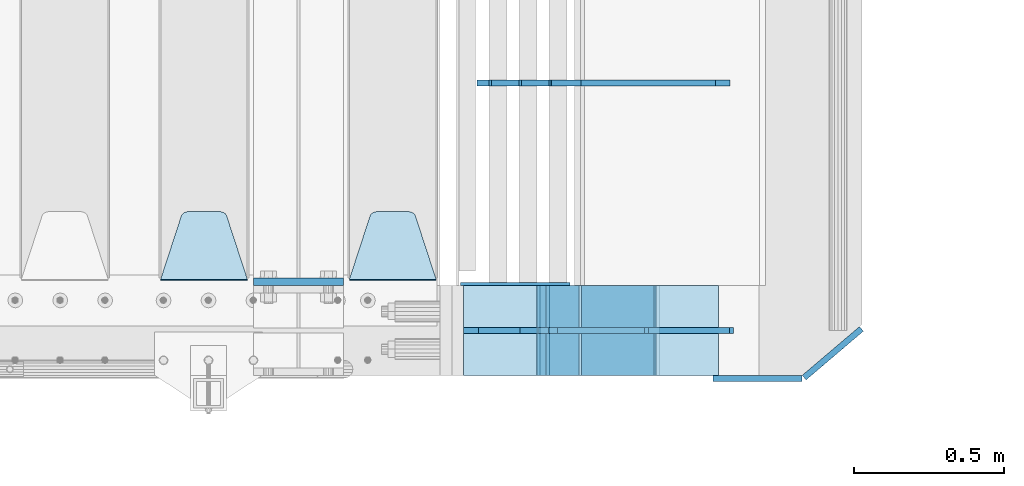
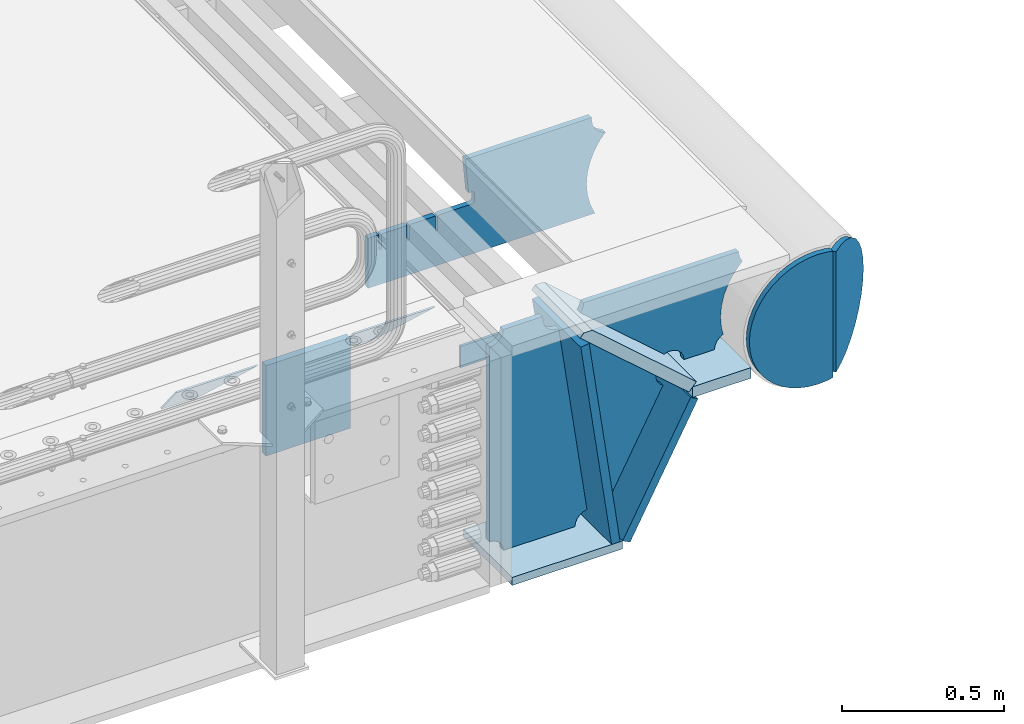
# One storey, part 224 of 247: 15 plates.
"""IFC2X3 building model written with IfcOpenShell, lengths in millimetres."""

from ifc_helpers import new_model, si_unit, frame, origin_with_axes, place, context, subcontext, project, spatial, faceted_brep, material, type_object, element, save


model = new_model("IFC2X3")

# Units and contexts
model_context = context("Model", 3, precision=1e-05, world=origin_with_axes())
body_context = subcontext(model_context, "Body", "Model", "MODEL_VIEW")
ifc_project = project(units=[si_unit("LENGTHUNIT", "METRE", prefix="MILLI"), si_unit("AREAUNIT", "SQUARE_METRE"), si_unit("VOLUMEUNIT", "CUBIC_METRE"), si_unit("MASSUNIT", "GRAM", prefix="KILO"), si_unit("TIMEUNIT", "SECOND"), si_unit("PLANEANGLEUNIT", "RADIAN"), si_unit("SOLIDANGLEUNIT", "STERADIAN"), si_unit("THERMODYNAMICTEMPERATUREUNIT", "DEGREE_CELSIUS"), si_unit("LUMINOUSINTENSITYUNIT", "LUMEN")], contexts=[model_context])

# Site, building, storey
site_placement = place(None, origin_with_axes())
site = spatial("IfcSite", under=ifc_project, at=site_placement, CompositionType="ELEMENT")
building_placement = place(site_placement, origin_with_axes())
building = spatial("IfcBuilding", under=site, at=building_placement, Name="Standard", CompositionType="ELEMENT")
storey_placement = place(building_placement, origin_with_axes())
storey = spatial("IfcBuildingStorey", under=building, at=storey_placement, Name="Undefined", CompositionType="ELEMENT", Elevation=0.0)

# Plates
ifc_material = material(Name="STEEL/S355N")
plate_type_1 = type_object("IfcPlateType", PredefinedType="NOTDEFINED")
plate_1_placement = place(storey_placement, frame((16195.0, 162.5, -340.000000000044), z_axis=(0.0, 0.0, 1.0), x_axis=(1.0, 0.0, 0.0)))
element("IfcPlate", 1, at=plate_1_placement, inside=storey, type_object=plate_type_1, material=ifc_material, context=body_context, shape_type="Brep", body=[
    faceted_brep([(0.0, -12.5, 0.0), (0.0, -12.5, 340.0), (0.0, 12.5, 340.0), (0.0, 12.5, 0.0), (300.0, -12.5, 340.0), (300.0, 12.5, 340.0), (300.0, -12.5, 0.0), (300.0, 12.5, 0.0)], [[[0, 1, 2, 3]], [[1, 4, 5, 2]], [[4, 6, 7, 5]], [[6, 0, 3, 7]], [[5, 7, 3, 2]], [[6, 4, 1, 0]]]),
])
plate_type_2 = type_object("IfcPlateType", PredefinedType="NOTDEFINED")
plate_2_placement = place(storey_placement, frame((16805.0, 168.232233047034, -1.76776695296758), z_axis=(0.0, 0.707106781186548, -0.707106781186547), x_axis=(-1.0, 0.0, 0.0)))
element("IfcPlate", 2, at=plate_2_placement, inside=storey, type_object=plate_type_2, material=ifc_material, context=body_context, shape_type="Brep", body=[
    faceted_brep([(0.0, -2.49999999999909, 0.0), (69.345504679477, -2.5, 300.17173142483), (69.345504679477, 2.50000000000091, 300.171731424831), (0.0, 2.5, -9.09494701772928e-13), (70.9274061199576, -2.5, 304.897442415399), (70.9274061199576, 2.50000000000091, 304.8974424154), (73.3818627772307, -2.49999999999909, 309.234538108527), (73.3818627772307, 2.5, 309.234538108526), (76.6187032999551, -2.5, 313.023683126102), (76.6187032999551, 2.50000000000091, 313.023683126102), (80.5190132704993, -2.49999999999909, 316.125672595371), (80.5190132704993, 2.50000000000091, 316.125672595372), (84.9395038596849, -2.49999999999909, 318.426546230476), (84.9395038596849, 2.5, 318.426546230475), (89.7177759439219, -2.5, 319.841774983274), (89.7177759439219, 2.50000000000091, 319.841774983275), (94.678286292652, -2.5, 320.319366455077), (94.678286292652, 2.50000000000091, 320.319366455077), (195.321713707348, -2.5, 320.319366455077), (195.321713707348, 2.50000000000091, 320.319366455077), (200.282224056078, -2.5, 319.841774983274), (200.282224056078, 2.50000000000091, 319.841774983275), (205.060496140315, -2.5, 318.426546230475), (205.060496140315, 2.5, 318.426546230474), (209.480986729501, -2.49999999999818, 316.12567259537), (209.480986729501, 2.50000000000091, 316.12567259537), (213.381296700045, -2.5, 313.023683126101), (213.381296700045, 2.50000000000091, 313.023683126101), (216.618137222769, -2.5, 309.234538108525), (216.618137222769, 2.5, 309.234538108525), (219.072593880042, -2.49999999999909, 304.897442415398), (219.072593880042, 2.5, 304.897442415398), (220.654495320523, -2.5, 300.17173142483), (220.654495320523, 2.50000000000091, 300.171731424831), (290.0, -2.49999999999909, 0.0), (290.0, 2.5, -9.09494701772928e-13)], [[[0, 1, 2, 3]], [[1, 4, 5, 2]], [[4, 6, 7, 5]], [[6, 8, 9, 7]], [[8, 10, 11, 9]], [[10, 12, 13, 11]], [[12, 14, 15, 13]], [[14, 16, 17, 15]], [[16, 18, 19, 17]], [[18, 20, 21, 19]], [[20, 22, 23, 21]], [[22, 24, 25, 23]], [[24, 26, 27, 25]], [[26, 28, 29, 27]], [[28, 30, 31, 29]], [[30, 32, 33, 31]], [[32, 34, 35, 33]], [[34, 0, 3, 35]], [[5, 7, 9, 11, 13, 15, 17, 19, 21, 23, 25, 27, 29, 31, 33, 35, 3, 2]], [[34, 32, 30, 28, 26, 24, 22, 20, 18, 16, 14, 12, 10, 8, 6, 4, 1, 0]]]),
])
plate_3_placement = place(storey_placement, frame((16175.0, 168.232233047034, -1.76776695296758), z_axis=(0.0, 0.707106781186548, -0.707106781186547), x_axis=(-1.0, 0.0, 0.0)))
element("IfcPlate", 3, at=plate_3_placement, inside=storey, type_object=plate_type_2, material=ifc_material, context=body_context, shape_type="Brep", body=[
    faceted_brep([(0.0, -2.49999999999909, 0.0), (69.345504679477, -2.5, 300.17173142483), (69.345504679477, 2.50000000000091, 300.171731424831), (0.0, 2.5, -9.09494701772928e-13), (70.9274061199576, -2.5, 304.897442415399), (70.9274061199576, 2.50000000000091, 304.8974424154), (73.3818627772307, -2.49999999999909, 309.234538108527), (73.3818627772307, 2.5, 309.234538108526), (76.6187032999551, -2.5, 313.023683126102), (76.6187032999551, 2.50000000000091, 313.023683126102), (80.5190132704993, -2.49999999999909, 316.125672595371), (80.5190132704993, 2.50000000000091, 316.125672595372), (84.9395038596849, -2.49999999999909, 318.426546230476), (84.9395038596849, 2.5, 318.426546230475), (89.7177759439219, -2.5, 319.841774983274), (89.7177759439219, 2.50000000000091, 319.841774983275), (94.678286292652, -2.5, 320.319366455077), (94.678286292652, 2.50000000000091, 320.319366455077), (195.321713707348, -2.5, 320.319366455077), (195.321713707348, 2.50000000000091, 320.319366455077), (200.282224056078, -2.5, 319.841774983274), (200.282224056078, 2.50000000000091, 319.841774983275), (205.060496140315, -2.5, 318.426546230475), (205.060496140315, 2.5, 318.426546230474), (209.480986729501, -2.49999999999818, 316.12567259537), (209.480986729501, 2.50000000000091, 316.12567259537), (213.381296700045, -2.5, 313.023683126101), (213.381296700045, 2.50000000000091, 313.023683126101), (216.618137222769, -2.5, 309.234538108525), (216.618137222769, 2.5, 309.234538108525), (219.072593880042, -2.49999999999909, 304.897442415398), (219.072593880042, 2.5, 304.897442415398), (220.654495320523, -2.5, 300.17173142483), (220.654495320523, 2.50000000000091, 300.171731424831), (290.0, -2.49999999999909, 0.0), (290.0, 2.5, -9.09494701772928e-13)], [[[0, 1, 2, 3]], [[1, 4, 5, 2]], [[4, 6, 7, 5]], [[6, 8, 9, 7]], [[8, 10, 11, 9]], [[10, 12, 13, 11]], [[12, 14, 15, 13]], [[14, 16, 17, 15]], [[16, 18, 19, 17]], [[18, 20, 21, 19]], [[20, 22, 23, 21]], [[22, 24, 25, 23]], [[24, 26, 27, 25]], [[26, 28, 29, 27]], [[28, 30, 31, 29]], [[30, 32, 33, 31]], [[32, 34, 35, 33]], [[34, 0, 3, 35]], [[5, 7, 9, 11, 13, 15, 17, 19, 21, 23, 25, 27, 29, 31, 33, 35, 3, 2]], [[34, 32, 30, 28, 26, 24, 22, 20, 18, 16, 14, 12, 10, 8, 6, 4, 1, 0]]]),
])
plate_type_3 = type_object("IfcPlateType", PredefinedType="NOTDEFINED")
plate_4_placement = place(storey_placement, frame((17538.9988298898, 149.9999999992, -367.999999998825), z_axis=(-0.752989422949573, 0.0, 0.658032619955933), x_axis=(0.0, -0.999999999999548, -9.5100000000016e-07)))
element("IfcPlate", 4, at=plate_4_placement, inside=storey, type_object=plate_type_3, material=ifc_material, context=body_context, shape_type="Brep", body=[
    faceted_brep([(-8.10757683211705e-10, 19.9999999999982, 490.766265601622), (4.54747350886464e-13, -0.303811250943909, 513.999999999998), (300.0, -0.303811250943909, 513.999999999998), (300.0, 19.9999999999982, 490.766265601622), (300.0, -20.0, -1.81898940354586e-12), (300.0, -20.0000000000018, 514.0), (4.54747350886464e-13, -20.0000000000018, 514.0), (0.0, -20.0, 0.0), (0.0, 20.0, 0.0), (300.0, 20.0, -1.81898940354586e-12)], [[[0, 1, 2, 3]], [[4, 5, 6, 7]], [[4, 7, 8, 9]], [[9, 8, 0, 3]], [[5, 4, 9, 3, 2]], [[6, 5, 2, 1]], [[8, 7, 6, 1, 0]]]),
])
plate_type_4 = type_object("IfcPlateType", PredefinedType="NOTDEFINED")
plate_5_placement = place(storey_placement, frame((17782.9182339676, 824.999282836914, -374.002067436517), z_axis=(0.0, 0.0, 1.0), x_axis=(-1.0, 0.0, 0.0)))
element("IfcPlate", 5, at=plate_5_placement, inside=storey, type_object=plate_type_4, material=ifc_material, context=body_context, shape_type="Brep", body=[
    faceted_brep([(801.919404066546, -10.0, 188.0), (801.919404066546, 10.0, 188.0), (801.919404066546, 10.0, 132.002067436952), (801.919404066546, -10.0, 132.002067436952), (793.919404066546, 10.0, 132.002067436952), (793.919404066546, -10.0, 132.002067436952), (793.919404066546, 10.0, 180.002067436952), (793.919404066546, -10.0, 180.002067436952), (793.527856196906, 10.0, 182.474203391951), (793.527856196906, -10.0, 182.474203391951), (792.391540021545, 10.0, 184.704349455291), (792.391540021545, -10.0, 184.704349455291), (790.621686084887, 10.0, 186.474203391951), (790.621686084887, -10.0, 186.474203391951), (788.391540021545, 10.0, 187.610519567313), (788.391540021545, -10.0, 187.610519567313), (785.919404066546, -10.0, 188.002067436952), (785.919404066546, 10.0, 188.0), (841.0, -10.0, 188.0), (841.0, -10.0, 0.0), (841.0, 10.0, 0.0), (841.0, 10.0, 188.0), (33.3619566736015, -10.0, 0.0), (33.3619566736015, 10.0, 0.0), (36.2350612208174, -10.0, 4.68848050267013), (36.2350612208174, 10.0, 4.68848050267013), (51.4877592159428, -10.0, 41.5117508652784), (51.4877592159428, 10.0, 41.5117508652784), (60.792242588137, -10.0, 80.2677133162964), (60.792242588137, 10.0, 80.2677133162964), (63.9194040769726, -10.0, 120.002067436515), (63.9194040769726, 10.0, 120.002067436515), (60.792242588137, -10.0, 159.736421556734), (60.792242588137, 10.0, 159.736421556734), (51.4877592159428, -10.0, 198.492384007752), (51.4877592159428, 10.0, 198.492384007752), (36.2350612208174, -10.0, 235.31565437036), (36.2350612208174, 10.0, 235.31565437036), (15.4097206482074, -10.0, 269.299521518803), (15.4097206482074, 10.0, 269.299521518803), (-3.35474438098754, -10.0, 291.269887256574), (-3.35474438098754, 10.0, 291.269887256574), (-2.36881039375294, -10.0, 291.426043859339), (-2.36881039375294, 10.0, 291.426043859339), (17.1449676604716, -10.0, 301.368810393754), (17.1449676604716, 10.0, 301.368810393754), (32.6311896062471, -10.0, 316.855032339527), (32.6311896062471, 10.0, 316.855032339527), (42.573956140659, -10.0, 336.368810393754), (42.573956140659, 10.0, 336.368810393754), (46.0, -10.0, 358.0), (46.0, 10.0, 358.0), (45.0495205499137, -10.0, 364.001091067617), (45.0495205499137, 10.0, 364.001091067617), (495.040008544922, -10.0, 364.010009765625), (495.040008544922, 10.0, 364.010009765625), (483.600036621094, -10.0, 233.759994506836), (483.600036621094, 10.0, 233.759994506836), (472.0, -10.0, 233.759994506836), (472.0, 10.0, 233.759994506836), (468.909830056251, -10.0, 233.270559669787), (468.909830056251, 10.0, 233.270559669787), (466.122147477075, -10.0, 231.850164450585), (466.122147477075, 10.0, 231.850164450585), (463.909830056251, -10.0, 229.637847029761), (463.909830056251, 10.0, 229.637847029761), (462.489434837047, -10.0, 226.850164450585), (462.489434837047, 10.0, 226.850164450585), (462.0, -10.0, 223.759994506836), (462.0, 10.0, 223.759994506836), (462.0, -10.0, 198.0), (462.0, 10.0, 198.0), (462.489434837047, -10.0, 194.909830056251), (462.489434837047, 10.0, 194.909830056251), (463.909830056251, -10.0, 192.122147477075), (463.909830056251, 10.0, 192.122147477075), (466.122147477075, -10.0, 189.909830056251), (466.122147477075, 10.0, 189.909830056251), (468.909830056251, -10.0, 188.489434837048), (468.909830056251, 10.0, 188.489434837048), (472.0, -10.0, 188.0), (472.0, 10.0, 188.0), (585.919404066546, -10.0, 188.002067436952), (585.919404066546, 10.0, 188.0), (588.391540021545, -10.0, 187.610519567313), (588.391540021545, 10.0, 187.610519567313), (590.621686084887, -10.0, 186.474203391951), (590.621686084887, 10.0, 186.474203391951), (592.391540021545, -10.0, 184.704349455291), (592.391540021545, 10.0, 184.704349455291), (593.527856196906, -10.0, 182.474203391951), (593.527856196906, 10.0, 182.474203391951), (593.919404066546, -10.0, 180.002067436952), (593.919404066546, 10.0, 180.002067436952), (593.919404066546, -10.0, 132.002067436952), (593.919404066546, 10.0, 132.002067436952), (601.919404066546, -10.0, 132.002067436952), (601.919404066546, 10.0, 132.002067436952), (601.919404066546, -10.0, 188.0), (601.919404066546, 10.0, 188.0), (685.919404066546, -10.0, 188.002067436952), (685.919404066546, 10.0, 188.0), (688.391540021545, -10.0, 187.610519567313), (688.391540021545, 10.0, 187.610519567313), (690.621686084887, -10.0, 186.474203391951), (690.621686084887, 10.0, 186.474203391951), (692.391540021545, -10.0, 184.704349455291), (692.391540021545, 10.0, 184.704349455291), (693.527856196906, -10.0, 182.474203391951), (693.527856196906, 10.0, 182.474203391951), (693.919404066546, -10.0, 180.002067436952), (693.919404066546, 10.0, 180.002067436952), (693.919404066546, -10.0, 132.002067436952), (693.919404066546, 10.0, 132.002067436952), (701.919404066546, -10.0, 132.002067436952), (701.919404066546, 10.0, 132.002067436952), (701.919404066546, -10.0, 188.0), (701.919404066546, 10.0, 188.0)], [[[0, 1, 2, 3]], [[3, 2, 4, 5]], [[5, 4, 6, 7]], [[7, 6, 8, 9]], [[9, 8, 10, 11]], [[11, 10, 12, 13]], [[13, 12, 14, 15]], [[16, 15, 14, 17]], [[18, 19, 20, 21]], [[20, 19, 22, 23]], [[22, 24, 25, 23]], [[26, 27, 25, 24]], [[28, 29, 27, 26]], [[30, 31, 29, 28]], [[32, 33, 31, 30]], [[34, 35, 33, 32]], [[36, 37, 35, 34]], [[38, 39, 37, 36]], [[39, 38, 40, 41]], [[40, 42, 43, 41]], [[44, 45, 43, 42]], [[46, 47, 45, 44]], [[48, 49, 47, 46]], [[50, 51, 49, 48]], [[52, 53, 51, 50]], [[54, 55, 53, 52]], [[54, 56, 57, 55]], [[56, 58, 59, 57]], [[58, 60, 61, 59]], [[60, 62, 63, 61]], [[62, 64, 65, 63]], [[64, 66, 67, 65]], [[66, 68, 69, 67]], [[68, 70, 71, 69]], [[70, 72, 73, 71]], [[72, 74, 75, 73]], [[74, 76, 77, 75]], [[76, 78, 79, 77]], [[78, 80, 81, 79]], [[81, 80, 82, 83]], [[82, 84, 85, 83]], [[86, 87, 85, 84]], [[88, 89, 87, 86]], [[90, 91, 89, 88]], [[92, 93, 91, 90]], [[94, 95, 93, 92]], [[96, 97, 95, 94]], [[98, 99, 97, 96]], [[99, 98, 100, 101]], [[100, 102, 103, 101]], [[104, 105, 103, 102]], [[106, 107, 105, 104]], [[108, 109, 107, 106]], [[110, 111, 109, 108]], [[112, 113, 111, 110]], [[114, 115, 113, 112]], [[116, 117, 115, 114]], [[117, 116, 16, 17]], [[12, 10, 8, 6, 4, 2, 1, 21, 20, 23, 25, 27, 29, 31, 33, 35, 37, 39, 41, 43, 45, 47, 49, 51, 53, 55, 57, 59, 61, 63, 65, 67, 69, 71, 73, 75, 77, 79, 81, 83, 85, 87, 89, 91, 93, 95, 97, 99, 101, 103, 105, 107, 109, 111, 113, 115, 117, 17, 14]], [[18, 21, 1, 0]], [[116, 114, 112, 110, 108, 106, 104, 102, 100, 98, 96, 94, 92, 90, 88, 86, 84, 82, 80, 78, 76, 74, 72, 70, 68, 66, 64, 62, 60, 58, 56, 54, 52, 50, 48, 46, 44, 42, 40, 38, 36, 34, 32, 30, 28, 26, 24, 22, 19, 18, 0, 3, 5, 7, 9, 11, 13, 15, 16]]]),
])
plate_type_5 = type_object("IfcPlateType", PredefinedType="NOTDEFINED")
plate_6_placement = place(storey_placement, frame((17538.9988298898, -150.000000000797, -387.999999998825), z_axis=(1.0, 0.0, 0.0), x_axis=(0.0, 1.0, 0.0)))
element("IfcPlate", 6, at=plate_6_placement, inside=storey, type_object=plate_type_5, material=ifc_material, context=body_context, shape_type="Brep", body=[
    faceted_brep([(0.0, -20.0, 0.0), (3.31056071445346e-10, -20.0, 208.0), (3.31056071445346e-10, 20.0, 208.0), (0.0, 20.0, 0.0), (300.0, -20.0, 208.0), (300.0, 20.0, 208.0), (300.0, -20.0, -1.81898940354586e-12), (300.0, 20.0, -1.81898940354586e-12)], [[[0, 1, 2, 3]], [[1, 4, 5, 2]], [[4, 6, 7, 5]], [[6, 0, 3, 7]], [[5, 7, 3, 2]], [[6, 4, 1, 0]]]),
])
plate_type_6 = type_object("IfcPlateType", PredefinedType="NOTDEFINED")
plate_7_placement = place(storey_placement, frame((17135.9988298891, 0.0, -30.0000000027761), z_axis=(0.0, 0.0, -1.0), x_axis=(-1.0, 0.0, 0.0)))
element("IfcPlate", 7, at=plate_7_placement, inside=storey, type_object=plate_type_6, material=ifc_material, context=body_context, shape_type="Brep", body=[
    faceted_brep([(-9.00602409638668, -10.0, 65.0), (-108.137843376921, -10.0, 780.473130459514), (-108.137843376921, 10.0, 780.473130459514), (-9.00602409638668, 10.0, 65.0), (-94.4157884488377, -10.0, 784.433672138112), (-94.4157884488377, 10.0, 784.433672138112), (-82.3732461236723, -10.0, 792.112074067144), (-82.3732461236723, 10.0, 792.112074067144), (-72.9927947992364, -10.0, 802.881837982249), (-72.9927947992364, 10.0, 802.881837982249), (-67.0398068183713, -10.0, 815.864234368775), (-67.0398068183713, 10.0, 815.864234368775), (-65.0, -10.0, 830.0), (-65.0, 10.0, 830.0), (189.0, -10.0, 830.0), (189.0, 10.0, 830.0), (191.447174185243, -10.0, 814.549150281253), (191.447174185243, 10.0, 814.549150281253), (198.549150281251, -10.0, 800.610737385376), (198.549150281251, 10.0, 800.610737385376), (209.610737385377, -10.0, 789.549150281253), (209.610737385377, 10.0, 789.549150281253), (223.549150281251, -10.0, 782.447174185242), (223.549150281251, 10.0, 782.447174185242), (239.0, -10.0, 780.0), (239.0, 10.0, 780.0), (239.0, -10.0, 50.0), (239.0, 10.0, 50.0), (223.549150281251, -10.0, 47.5528258147577), (223.549150281251, 10.0, 47.5528258147577), (209.610737385377, -10.0, 40.4508497187474), (209.610737385377, 10.0, 40.4508497187474), (198.549150281251, -10.0, 29.3892626146237), (198.549150281251, 10.0, 29.3892626146237), (191.447174185243, -10.0, 15.4508497187474), (191.447174185243, 10.0, 15.4508497187474), (189.0, -10.0, 0.0), (189.0, 10.0, 0.0), (50.4776502774184, -10.0, 0.0), (50.4776502774184, 10.0, 0.0), (47.3830020671812, -10.0, 22.3352870825933), (47.3830020671812, 10.0, 22.3352870825933), (42.8384615202776, -10.0, 37.3040735979326), (42.8384615202776, 10.0, 37.3040735979326), (33.8907372011709, -10.0, 50.1358952937587), (33.8907372011709, 10.0, 50.1358952937587), (21.4156947086703, -10.0, 59.5746840579253), (21.4156947086703, 10.0, 59.5746840579253), (6.63447812067898, -10.0, 64.6965054822873), (6.63447812067898, 10.0, 64.6965054822873)], [[[0, 1, 2, 3]], [[1, 4, 5, 2]], [[4, 6, 7, 5]], [[6, 8, 9, 7]], [[8, 10, 11, 9]], [[10, 12, 13, 11]], [[12, 14, 15, 13]], [[14, 16, 17, 15]], [[16, 18, 19, 17]], [[18, 20, 21, 19]], [[20, 22, 23, 21]], [[22, 24, 25, 23]], [[24, 26, 27, 25]], [[26, 28, 29, 27]], [[28, 30, 31, 29]], [[30, 32, 33, 31]], [[32, 34, 35, 33]], [[34, 36, 37, 35]], [[36, 38, 39, 37]], [[38, 40, 41, 39]], [[40, 42, 43, 41]], [[42, 44, 45, 43]], [[44, 46, 47, 45]], [[46, 48, 49, 47]], [[48, 0, 3, 49]], [[5, 7, 9, 11, 13, 15, 17, 19, 21, 23, 25, 27, 29, 31, 33, 35, 37, 39, 41, 43, 45, 47, 49, 3, 2]], [[48, 46, 44, 42, 40, 38, 36, 34, 32, 30, 28, 26, 24, 22, 20, 18, 16, 14, 12, 10, 8, 6, 4, 1, 0]]]),
])
plate_type_7 = type_object("IfcPlateType", PredefinedType="NOTDEFINED")
plate_8_placement = place(storey_placement, frame((17853.9988298898, -6.40284270048141e-10, -29.9999999988253), z_axis=(-0.000446694000102124, 0.0, -0.99999990023223), x_axis=(-0.99999990023223, 0.0, 0.000446694000103734)))
element("IfcPlate", 8, at=plate_8_placement, inside=storey, type_object=plate_type_7, material=ifc_material, context=body_context, shape_type="Brep", body=[
    faceted_brep([(125.007775472979, 10.0, 291.842314882029), (131.755016800053, 10.0, 263.793234614468), (131.755016800053, -10.0, 263.793234614468), (125.007775472979, -10.0, 291.842314882029), (134.899927074483, 10.0, 224.060281342732), (134.899927074483, -10.0, 224.060281342732), (131.79051499522, 10.0, 184.324534302446), (131.79051499522, -10.0, 184.324534302446), (122.503344607208, 10.0, 145.564419461128), (122.503344607208, -10.0, 145.564419461128), (107.267096867745, 10.0, 108.734339483615), (107.267096867745, -10.0, 108.734339483615), (86.4569387623887, 10.0, 74.741173170983), (86.4569387623887, -10.0, 74.741173170983), (60.5852854486511, 10.0, 44.4219450946983), (60.5852854486511, -10.0, 44.4219450946983), (56.2519855253086, 10.0, 40.7176084148895), (56.2519855253086, -10.0, 40.7176084148895), (136.409234539125, -10.0, 297.721677540594), (147.386991180581, -10.0, 308.778803581017), (147.386991180581, 10.0, 308.778803581017), (136.409234539125, 10.0, 297.721677540594), (154.428166132755, -10.0, 322.678193223937), (154.428166132755, 10.0, 322.678193223937), (156.849001662977, -10.0, 338.070097995228), (156.849001662977, 10.0, 338.070097995228), (264.849004013293, -10.0, 338.118348049693), (264.849004013293, 10.0, 338.118348049693), (267.62876711955, -10.0, 321.701412969031), (267.62876711955, 10.0, 321.701412969031), (275.645118712178, -10.0, 307.107546191754), (275.645118712178, 10.0, 307.107546191754), (288.009068357209, -10.0, 295.955165748785), (288.009068357209, 10.0, 295.955165748785), (303.349489447533, -10.0, 289.481038692482), (303.349489447533, 10.0, 289.481038692482), (319.965173216926, -10.0, 288.403127172445), (319.965173216926, 10.0, 288.403127172445), (336.013487920231, -10.0, 292.840968489265), (336.013487920231, 10.0, 292.840968489265), (335.869079589844, -10.0, 293.150054931641), (335.869079589844, 10.0, 293.150054931641), (633.937057436444, -10.0, 32.8861672876965), (633.937057436444, 10.0, 32.8861672876965), (628.672097726401, -10.0, 25.6357574923157), (628.672097726401, 10.0, 25.6357574923157), (624.785781531271, -10.0, 17.5620477266101), (624.785781531271, 10.0, 17.5620477266101), (622.402919050601, -10.0, 8.92432757904926), (622.402919050601, 10.0, 8.92432757904926), (621.600036621097, -10.0, -8.74678107720683e-10), (621.600036621097, 10.0, -8.74678107720683e-10), (70.0, -10.0, -9.84989867447439e-11), (70.0, 10.0, -9.84989867447439e-11), (67.7728137216618, -10.0, 17.5170123094482), (67.7728137216618, 10.0, 17.5170123094482), (61.2329794213983, -10.0, 33.9193489203215), (61.2329794213983, 10.0, 33.9193489203215)], [[[0, 1, 2, 3]], [[4, 5, 2, 1]], [[6, 7, 5, 4]], [[8, 9, 7, 6]], [[10, 11, 9, 8]], [[12, 13, 11, 10]], [[14, 15, 13, 12]], [[16, 17, 15, 14]], [[18, 19, 20, 21]], [[19, 22, 23, 20]], [[22, 24, 25, 23]], [[24, 26, 27, 25]], [[26, 28, 29, 27]], [[28, 30, 31, 29]], [[30, 32, 33, 31]], [[32, 34, 35, 33]], [[34, 36, 37, 35]], [[36, 38, 39, 37]], [[38, 40, 41, 39]], [[40, 42, 43, 41]], [[42, 44, 45, 43]], [[44, 46, 47, 45]], [[46, 48, 49, 47]], [[48, 50, 51, 49]], [[50, 52, 53, 51]], [[52, 54, 55, 53]], [[54, 56, 57, 55]], [[12, 10, 8, 6, 4, 1, 0, 21, 20, 23, 25, 27, 29, 31, 33, 35, 37, 39, 41, 43, 45, 47, 49, 51, 53, 55, 57, 16, 14]], [[18, 21, 0, 3]], [[56, 54, 52, 50, 48, 46, 44, 42, 40, 38, 36, 34, 32, 30, 28, 26, 24, 22, 19, 18, 3, 2, 5, 7, 9, 11, 13, 15, 17]], [[57, 56, 17, 16]]]),
])
plate_type_8 = type_object("IfcPlateType", PredefinedType="NOTDEFINED")
plate_9_placement = place(storey_placement, frame((17538.0025685034, 1.00408215075731e-09, -393.99668820393), z_axis=(-0.658066357015091, 0.0, -0.752959939017267), x_axis=(-0.752959939017266, 0.0, 0.658066357015093)))
element("IfcPlate", 9, at=plate_9_placement, inside=storey, type_object=plate_type_8, material=ifc_material, context=body_context, shape_type="Brep", body=[
    faceted_brep([(-11.3595226159596, -10.0, 48.6925173505915), (-112.015767301031, -10.0, 480.154833723631), (-112.015767301031, 10.0, 480.154833723631), (-11.3595226159596, 10.0, 48.6925173505915), (-104.567323293641, -10.0, 482.519601382541), (-104.567323293641, 10.0, 482.519601382541), (-97.5783311599971, -10.0, 486.016090073756), (-97.5783311599971, 10.0, 486.016090073756), (-91.2195220373815, -10.0, 490.558885551654), (-91.2195220373815, 10.0, 490.558885551654), (-85.646232588424, -10.0, 496.037013784004), (-85.646232588424, 10.0, 496.037013784004), (447.024482710494, -10.0, 32.8103372896385), (447.024482710494, 10.0, 32.8103372896385), (441.786973010396, -10.0, 25.5709623937291), (441.786973010396, 10.0, 25.5709623937291), (437.921644570128, -10.0, 17.5149526624118), (437.921644570128, 10.0, 17.5149526624118), (435.551940606496, -10.0, 8.89958500531793), (435.551940606496, 10.0, 8.89958500531793), (434.753540039063, -10.0, -5.16592990607023e-10), (434.753540039063, 10.0, -5.16592990607023e-10), (50.0, -10.0, 0.0), (50.0, 10.0, 0.0), (47.7668538974231, -10.0, 14.7759151575174), (47.7668538974231, 10.0, 14.7759151575174), (41.2668932502802, -10.0, 28.2319592212443), (41.2668932502802, 10.0, 28.2319592212443), (31.0807325300175, -10.0, 39.1661596968297), (31.0807325300175, 10.0, 39.1661596968297), (18.1182591411507, -10.0, 46.6018098971963), (18.1182591411507, 10.0, 46.6018098971963), (3.5373569608073, -10.0, 49.874714091733), (3.5373569608073, 10.0, 49.874714091733)], [[[0, 1, 2, 3]], [[1, 4, 5, 2]], [[4, 6, 7, 5]], [[6, 8, 9, 7]], [[8, 10, 11, 9]], [[10, 12, 13, 11]], [[12, 14, 15, 13]], [[14, 16, 17, 15]], [[16, 18, 19, 17]], [[18, 20, 21, 19]], [[20, 22, 23, 21]], [[22, 24, 25, 23]], [[24, 26, 27, 25]], [[26, 28, 29, 27]], [[28, 30, 31, 29]], [[30, 32, 33, 31]], [[32, 0, 3, 33]], [[5, 7, 9, 11, 13, 15, 17, 19, 21, 23, 25, 27, 29, 31, 33, 3, 2]], [[32, 30, 28, 26, 24, 22, 20, 18, 16, 14, 12, 10, 8, 6, 4, 1, 0]]]),
])
plate_type_9 = type_object("IfcPlateType", PredefinedType="NOTDEFINED")
plate_10_placement = place(storey_placement, frame((17289.9988298891, 150.0, -875.000000002776), z_axis=(0.0, -0.999999999999548, -9.5100000000016e-07), x_axis=(-1.0, 0.0, 0.0)))
element("IfcPlate", 10, at=plate_10_placement, inside=storey, type_object=plate_type_9, material=ifc_material, context=body_context, shape_type="Brep", body=[
    faceted_brep([(0.0, -15.0, 0.0), (0.0, -15.0, 300.0), (0.0, 15.0, 300.0), (0.0, 15.0, 0.0), (393.0, -15.0, 300.0), (393.0, 15.0, 300.0), (393.0, -15.0, 1.50635059981141e-12), (393.0, 15.0, 1.50635059981141e-12)], [[[0, 1, 2, 3]], [[1, 4, 5, 2]], [[4, 6, 7, 5]], [[6, 0, 3, 7]], [[5, 7, 3, 2]], [[6, 4, 1, 0]]]),
])
plate_11_placement = place(storey_placement, frame((17266.1480677228, 150.000000001004, -862.083788726918), z_axis=(-0.139173011053008, 0.0, 0.990268081377179), x_axis=(0.0, -0.999999999999548, -9.5100000000016e-07)))
element("IfcPlate", 11, at=plate_11_placement, inside=storey, type_object=plate_type_9, material=ifc_material, context=body_context, shape_type="Brep", body=[
    faceted_brep([(1.00411057246674e-09, 14.9994702460535, -0.00376939767329532), (300.0, 15.0, 0.0), (300.0, -15.0, 4.21237841386937), (0.0, -15.0, 4.21237841386937), (0.0, -14.9999999999964, 792.0), (300.0, -14.9999999999964, 792.0), (300.0, 15.0, 792.0), (0.0, 15.0, 792.0)], [[[0, 1, 2, 3]], [[4, 5, 6, 7]], [[4, 7, 0, 3]], [[5, 4, 3, 2]], [[6, 5, 2, 1]], [[7, 6, 1, 0]]]),
])
plate_12_placement = place(storey_placement, frame((17303.2468009574, 150.000000001004, -867.03875473756), z_axis=(0.469471552246176, 0.0, 0.882947598462992), x_axis=(0.0, -0.999999999999548, -9.5100000000016e-07)))
element("IfcPlate", 12, at=plate_12_placement, inside=storey, type_object=plate_type_9, material=ifc_material, context=body_context, shape_type="Brep", body=[
    faceted_brep([(0.0, -15.0, 0.0), (0.0, -15.0, 514.999999999999), (0.0, 15.0000000000018, 515.000000000001), (0.0, 15.0, 0.0), (300.0, -15.0, 514.999999999999), (300.0, 15.0000000000018, 515.000000000001), (300.0, -15.0, 0.0), (300.0, 15.0, 0.0)], [[[0, 1, 2, 3]], [[1, 4, 5, 2]], [[4, 6, 7, 5]], [[6, 0, 3, 7]], [[5, 7, 3, 2]], [[6, 4, 1, 0]]]),
])
plate_type_10 = type_object("IfcPlateType", PredefinedType="NOTDEFINED")
plate_13_placement = place(storey_placement, frame((18217.0025260065, -160.0, -498.0), z_axis=(0.0, 0.0, 1.0), x_axis=(-1.0, 0.0, 0.0)))
element("IfcPlate", 13, at=plate_13_placement, inside=storey, type_object=plate_type_10, material=ifc_material, context=body_context, shape_type="Brep", body=[
    faceted_brep([(244.0, -10.0, 0.0), (209.275179461318, -10.0, 2.48356818105242), (209.275179461318, 10.0, 2.48356818105242), (244.0, 10.0, 0.0), (278.724820538682, -10.0, 2.48356818105236), (278.724820538682, 10.0, 2.48356818105236), (312.742743869308, -10.0, 9.88371443806261), (312.742743869308, 10.0, 9.88371443806261), (345.361263172461, -10.0, 22.0497931334975), (345.361263172461, 10.0, 22.0497931334975), (375.916359459166, -10.0, 38.7341379891918), (375.916359459166, 10.0, 38.7341379891918), (403.78601908265, -10.0, 59.597103857561), (403.78601908265, 10.0, 59.597103857561), (428.402896142437, -10.0, 84.2139809173505), (428.402896142437, 10.0, 84.2139809173505), (449.265862010809, -10.0, 112.083640540834), (449.265862010809, 10.0, 112.083640540834), (465.950206866502, -10.0, 142.63873682754), (465.950206866502, 10.0, 142.63873682754), (478.116285561937, -10.0, 175.257256130691), (478.116285561937, 10.0, 175.257256130691), (485.516431818949, -10.0, 209.275179461318), (485.516431818949, 10.0, 209.275179461318), (488.0, -10.0, 244.0), (488.0, 10.0, 244.0), (485.516431818949, -10.0, 278.724820538682), (485.516431818949, 10.0, 278.724820538682), (478.116285561937, -10.0, 312.742743869309), (478.116285561937, 10.0, 312.742743869309), (465.950206866502, -10.0, 345.36126317246), (465.950206866502, 10.0, 345.36126317246), (449.265862010809, -10.0, 375.916359459166), (449.265862010809, 10.0, 375.916359459166), (428.402896142437, -10.0, 403.78601908265), (428.402896142437, 10.0, 403.78601908265), (403.78601908265, -10.0, 428.402896142439), (403.78601908265, 10.0, 428.402896142439), (375.916359459166, -10.0, 449.265862010808), (375.916359459166, 10.0, 449.265862010808), (345.361263172461, -10.0, 465.950206866503), (345.361263172461, 10.0, 465.950206866503), (312.742743869308, -10.0, 478.116285561937), (312.742743869308, 10.0, 478.116285561937), (278.724820538682, -10.0, 485.516431818948), (278.724820538682, 10.0, 485.516431818948), (244.0, -10.0, 488.0), (244.0, 10.0, 488.0), (209.275179461318, -10.0, 485.516431818948), (209.275179461318, 10.0, 485.516431818948), (190.054561198212, -10.0, 481.33524224677), (190.05769402791, -10.0, 6.66407624784438), (190.062244034561, 10.0, 6.6630864544826), (190.0591111918, 10.0, 481.33623203729)], [[[0, 1, 2, 3]], [[4, 0, 3, 5]], [[6, 4, 5, 7]], [[8, 6, 7, 9]], [[10, 8, 9, 11]], [[12, 10, 11, 13]], [[14, 12, 13, 15]], [[16, 14, 15, 17]], [[18, 16, 17, 19]], [[20, 18, 19, 21]], [[22, 20, 21, 23]], [[24, 22, 23, 25]], [[26, 24, 25, 27]], [[28, 26, 27, 29]], [[30, 28, 29, 31]], [[32, 30, 31, 33]], [[34, 32, 33, 35]], [[36, 34, 35, 37]], [[38, 36, 37, 39]], [[40, 38, 39, 41]], [[42, 40, 41, 43]], [[44, 42, 43, 45]], [[46, 44, 45, 47]], [[48, 46, 47, 49]], [[1, 0, 4, 6, 8, 10, 12, 14, 16, 18, 20, 22, 24, 26, 28, 30, 32, 34, 36, 38, 40, 42, 44, 46, 48, 50, 51]], [[2, 1, 51, 52]], [[49, 47, 45, 43, 41, 39, 37, 35, 33, 31, 29, 27, 25, 23, 21, 19, 17, 15, 13, 11, 9, 7, 5, 3, 2, 52, 53]], [[48, 49, 53, 50]], [[52, 51, 50, 53]]]),
])
plate_type_11 = type_object("IfcPlateType", PredefinedType="NOTDEFINED")
plate_14_placement = place(storey_placement, frame((17251.998829901, 155.0, -249.999999999564), z_axis=(-1.0, 0.0, 0.0), x_axis=(0.0, 0.0, 1.0)))
element("IfcPlate", 14, at=plate_14_placement, inside=storey, type_object=plate_type_11, material=ifc_material, context=body_context, shape_type="Brep", body=[
    faceted_brep([(9.04219632502645e-09, -5.00000000143385, -2.89173840428703e-09), (0.0, -5.0, 365.0), (0.0, 5.0, 365.0), (7.66340235713869e-09, 4.99999999856618, -2.89173840428703e-09), (80.0, -5.0, 365.0), (80.0, 5.0, 365.0), (80.0, -5.0, 0.0), (80.0, 5.0, 0.0)], [[[0, 1, 2, 3]], [[1, 4, 5, 2]], [[4, 6, 7, 5]], [[6, 0, 3, 7]], [[5, 7, 3, 2]], [[6, 4, 1, 0]]]),
])
plate_type_12 = type_object("IfcPlateType", PredefinedType="NOTDEFINED")
plate_15_placement = place(storey_placement, frame((18070.671855575, -125.949252007551, -30.6102092804317), z_axis=(-0.0672019629768904, -0.057352245980278, -0.996089662657469), x_axis=(-0.758955820878056, -0.645120692896348, 0.088347911985805)))
element("IfcPlate", 15, at=plate_15_placement, inside=storey, type_object=plate_type_12, material=ifc_material, context=body_context, shape_type="Brep", body=[
    faceted_brep([(-5.6843418860808e-14, -9.99999999999989, 3.5527136788005e-15), (-48.0487670880721, -10.0000000000018, 8.67017459869362), (-48.0487670880702, 9.99999999999636, 8.67017459869362), (-5.6843418860808e-14, 10.0000000000001, 3.5527136788005e-15), (-93.1333465523603, -10.0000000000018, 25.6771621704102), (-93.1333465523621, 9.99999999999636, 25.6771621704099), (-133.522018422309, -10.0000000000036, 50.3669776916502), (-133.522018422307, 9.99999999999818, 50.3669776916504), (-167.658004743997, -10.0, 81.7919921875), (-167.658004743997, 10.0, 81.7919921875), (-194.131179785258, -10.0000000000018, 118.752670288086), (-194.13117978526, 9.99999999999636, 118.752670288085), (-212.241073575682, -10.0000000000018, 159.800354003906), (-212.241073575684, 10.0, 159.800354003906), (-220.965927082383, -10.0000000000018, 203.387512207031), (-220.965927082385, 9.99999999999636, 203.387512207031), (-220.078811594771, -10.0000000000018, 247.828140258789), (-220.078811594769, 10.0, 247.828140258789), (-209.490798890534, -10.0, 291.42642211914), (-209.490798890531, 10.0, 291.426422119141), (-189.979858330371, -10.0, 332.473327636719), (-189.979858330373, 9.99999999999818, 332.473327636719), (-161.93486015386, -10.0, 369.42398071289), (-161.934860153862, 9.99999999999818, 369.42398071289), (-126.533912576628, -10.0000000000018, 400.848876953125), (-126.533912576626, 9.99999999999818, 400.848876953125), (-85.1552428328014, -10.0, 425.539093017578), (-85.1552428328014, 9.99999999999818, 425.539093017578), (-39.3886450815153, -10.0000000000018, 442.546478271484), (-39.3886450815171, 9.99999999999818, 442.546478271484), (8.99617299734564, -10.0, 451.215240478515), (8.99617299734382, 9.99999999999818, 451.215240478515), (49.1690940856952, -10.0, -2.97859514830634e-11), (49.1690940856934, 9.99999999999818, -2.97859514830634e-11)], [[[0, 1, 2, 3]], [[1, 4, 5, 2]], [[4, 6, 7, 5]], [[6, 8, 9, 7]], [[8, 10, 11, 9]], [[10, 12, 13, 11]], [[12, 14, 15, 13]], [[14, 16, 17, 15]], [[16, 18, 19, 17]], [[18, 20, 21, 19]], [[20, 22, 23, 21]], [[22, 24, 25, 23]], [[24, 26, 27, 25]], [[26, 28, 29, 27]], [[28, 30, 31, 29]], [[30, 32, 33, 31]], [[32, 0, 3, 33]], [[5, 7, 9, 11, 13, 15, 17, 19, 21, 23, 25, 27, 29, 31, 33, 3, 2]], [[32, 30, 28, 26, 24, 22, 20, 18, 16, 14, 12, 10, 8, 6, 4, 1, 0]]]),
])

save(model, "model.ifc")
